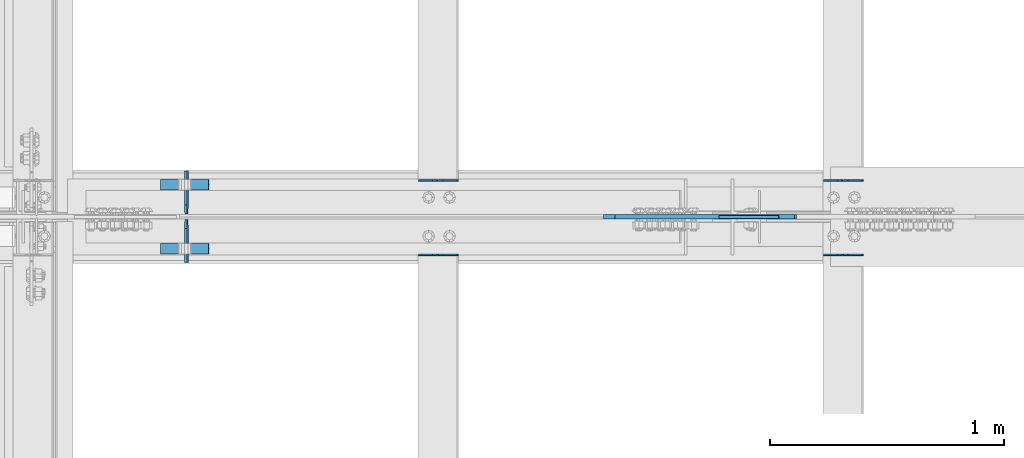
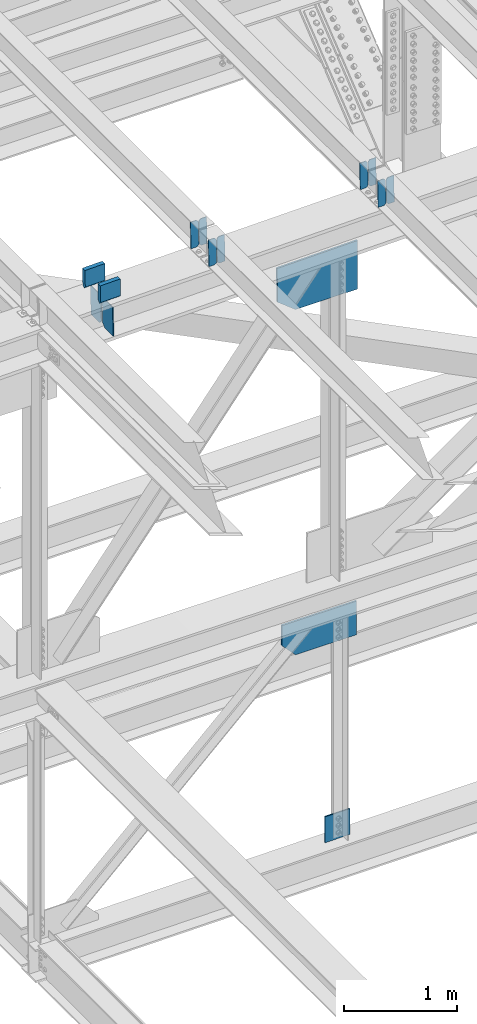
# One storey, part 3610 of 3843: 15 plates, 7 elements without a shape of their own.
"""IFC2X3 building model written with IfcOpenShell, lengths in millimetres."""

from ifc_helpers import new_model, si_unit, frame, origin_with_axes, place, context, subcontext, project, spatial, faceted_brep, material, type_object, element, aggregate, save


model = new_model("IFC2X3")

# Units and contexts
model_context = context("Model", 3, precision=1e-05, world=origin_with_axes())
body_context = subcontext(model_context, "Body", "Model", "MODEL_VIEW")
ifc_project = project(units=[si_unit("LENGTHUNIT", "METRE", prefix="MILLI"), si_unit("AREAUNIT", "SQUARE_METRE"), si_unit("VOLUMEUNIT", "CUBIC_METRE"), si_unit("MASSUNIT", "GRAM", prefix="KILO"), si_unit("TIMEUNIT", "SECOND"), si_unit("PLANEANGLEUNIT", "RADIAN"), si_unit("SOLIDANGLEUNIT", "STERADIAN"), si_unit("THERMODYNAMICTEMPERATUREUNIT", "DEGREE_CELSIUS"), si_unit("LUMINOUSINTENSITYUNIT", "LUMEN")], contexts=[model_context])

# Site, building, storey
site_placement = place(None, origin_with_axes())
site = spatial("IfcSite", under=ifc_project, at=site_placement, CompositionType="ELEMENT")
building_placement = place(site_placement, origin_with_axes())
building = spatial("IfcBuilding", under=site, at=building_placement, Name="Undefined", CompositionType="ELEMENT")
storey_placement = place(building_placement, origin_with_axes())
storey = spatial("IfcBuildingStorey", under=building, at=storey_placement, Name="Undefined", CompositionType="ELEMENT", Elevation=0.0)

# Assembly, plates
assembly_1_placement = place(storey_placement, origin_with_axes())
assembly_1 = element("IfcElementAssembly", 1, at=assembly_1_placement, inside=storey, Name="BEAM", AssemblyPlace="NOTDEFINED", PredefinedType="RIGID_FRAME")
ifc_material = material(Name="STEEL/A572-50")
plate_type_1 = type_object("IfcPlateType", PredefinedType="NOTDEFINED")
plate_1_placement = place(assembly_1_placement, frame((80549.496663406, 67426.8308424063, 46443.9500918996), z_axis=(-0.021152098224542, 0.00215704300087236, 0.999773942402077), x_axis=(-0.999776269356297, -4.57939999836346e-05, -0.021152048007558)))
plate_1 = element("IfcPlate", 2, at=plate_1_placement, type_object=plate_type_1, material=ifc_material, Name="PLATE", context=body_context, shape_type="Brep", body=[
    faceted_brep([(0.0, -3.17499999999927, 0.0), (6.83940015733242e-10, -3.17499999996653, 288.924999998613), (6.54836185276508e-10, 3.17500000001746, 288.924999998591), (0.0, 3.17499999999927, 0.0), (60.3250007643655, -3.17500000017753, 288.924999998606), (60.3250007643219, 3.17499999979918, 288.924999998584), (79.3750000013097, -3.17500000025029, 269.875000761494), (79.375000001266, 3.17499999972642, 269.875000761487), (79.375000000713, -3.17500000026484, 19.0499992370605), (79.3750000006985, 3.17499999971187, 19.0499992370533), (60.325000763667, -3.17500000020664, -1.45519152283669e-11), (60.3250007636234, 3.17499999977736, -3.63797880709171e-11)], [[[0, 1, 2, 3]], [[1, 4, 5, 2]], [[4, 6, 7, 5]], [[6, 8, 9, 7]], [[8, 10, 11, 9]], [[10, 0, 3, 11]], [[5, 7, 9, 11, 3, 2]], [[10, 8, 6, 4, 1, 0]]]),
])
plate_2_placement = place(assembly_1_placement, frame((80463.7908427148, 67426.8269307585, 46442.1368325162), z_axis=(-0.021152098224542, 0.00215704300087236, 0.999773942402077), x_axis=(-0.999776269356297, -4.57939999836346e-05, -0.021152048007558)))
plate_2 = element("IfcPlate", 3, at=plate_2_placement, type_object=plate_type_1, material=ifc_material, Name="PLATE", context=body_context, shape_type="Brep", body=[
    faceted_brep([(4.36557456851006e-11, -3.17499999998836, 19.0499992370969), (6.11180439591408e-10, -3.17499999996653, 269.875000761516), (5.96628524363041e-10, 3.17500000001746, 269.875000761502), (1.45519152283669e-11, 3.17499999998836, 19.0499992370824), (19.0499992376572, -3.17500000003201, 288.924999998606), (19.0499992376281, 3.1749999999447, 288.924999998584), (79.3750000013242, -3.17500000025029, 288.924999998591), (79.3750000013097, 3.1749999997337, 288.92499999857), (79.3750000006548, -3.17500000026484, -2.18278728425503e-11), (79.3750000006403, 3.17499999969732, -2.91038304567337e-11), (19.0499992370023, -3.17500000005384, 0.0), (19.0499992369587, 3.17499999992287, -1.45519152283669e-11)], [[[0, 1, 2, 3]], [[1, 4, 5, 2]], [[4, 6, 7, 5]], [[6, 8, 9, 7]], [[8, 10, 11, 9]], [[10, 0, 3, 11]], [[5, 7, 9, 11, 3, 2]], [[10, 8, 6, 4, 1, 0]]]),
])
aggregate(assembly_1, [plate_1, plate_2])

assembly_2_placement = place(storey_placement, origin_with_axes())
assembly_2 = element("IfcElementAssembly", 4, at=assembly_2_placement, inside=storey, Name="BEAM", AssemblyPlace="NOTDEFINED", PredefinedType="RIGID_FRAME")
plate_3_placement = place(assembly_2_placement, frame((80549.4966586625, 67109.7846024204, 46444.3868867662), z_axis=(-0.0211520982257644, 0.00063245100018685, 0.999776069300711), x_axis=(-0.999776269350183, -1.43399999262055e-05, -0.021152093007418)))
plate_3 = element("IfcPlate", 5, at=plate_3_placement, type_object=plate_type_1, material=ifc_material, Name="PLATE", context=body_context, shape_type="Brep", body=[
    faceted_brep([(0.0, -3.17499999999927, 0.0), (6.83940015733242e-10, -3.17499999996653, 288.924999998613), (6.54836185276508e-10, 3.17500000001746, 288.924999998591), (0.0, 3.17499999999927, 0.0), (60.3250007643655, -3.17500000017753, 288.924999998606), (60.3250007643219, 3.17499999979918, 288.924999998584), (79.3750000013097, -3.17500000025029, 269.875000761494), (79.375000001266, 3.17499999972642, 269.875000761487), (79.375000000713, -3.17500000026484, 19.0499992370605), (79.3750000006985, 3.17499999971187, 19.0499992370533), (60.325000763667, -3.17500000020664, -1.45519152283669e-11), (60.3250007636234, 3.17499999977736, -3.63797880709171e-11)], [[[0, 1, 2, 3]], [[1, 4, 5, 2]], [[4, 6, 7, 5]], [[6, 8, 9, 7]], [[8, 10, 11, 9]], [[10, 0, 3, 11]], [[5, 7, 9, 11, 3, 2]], [[10, 8, 6, 4, 1, 0]]]),
])
plate_4_placement = place(assembly_2_placement, frame((80463.7908379713, 67109.7834572489, 46442.5736235265), z_axis=(-0.0211520982257644, 0.00063245100018685, 0.999776069300711), x_axis=(-0.999776269350183, -1.43399999262055e-05, -0.021152093007418)))
plate_4 = element("IfcPlate", 6, at=plate_4_placement, type_object=plate_type_1, material=ifc_material, Name="PLATE", context=body_context, shape_type="Brep", body=[
    faceted_brep([(4.36557456851006e-11, -3.17499999998836, 19.0499992370969), (6.11180439591408e-10, -3.17499999996653, 269.875000761516), (5.96628524363041e-10, 3.17500000001746, 269.875000761502), (1.45519152283669e-11, 3.17499999998836, 19.0499992370824), (19.0499992376572, -3.17500000003201, 288.924999998606), (19.0499992376281, 3.1749999999447, 288.924999998584), (79.3750000013242, -3.17500000025029, 288.924999998591), (79.3750000013097, 3.1749999997337, 288.92499999857), (79.3750000006548, -3.17500000026484, -2.18278728425503e-11), (79.3750000006403, 3.17499999969732, -2.91038304567337e-11), (19.0499992370023, -3.17500000005384, 0.0), (19.0499992369587, 3.17499999992287, -1.45519152283669e-11)], [[[0, 1, 2, 3]], [[1, 4, 5, 2]], [[4, 6, 7, 5]], [[6, 8, 9, 7]], [[8, 10, 11, 9]], [[10, 0, 3, 11]], [[5, 7, 9, 11, 3, 2]], [[10, 8, 6, 4, 1, 0]]]),
])
aggregate(assembly_2, [plate_3, plate_4])

assembly_3_placement = place(storey_placement, origin_with_axes())
assembly_3 = element("IfcElementAssembly", 7, at=assembly_3_placement, inside=storey, Name="BEAM", AssemblyPlace="NOTDEFINED", PredefinedType="RIGID_FRAME")
plate_5_placement = place(assembly_3_placement, frame((78822.2966634333, 67426.8284519226, 46410.260581113), z_axis=(-0.02115209757931, 0.00216448800069338, 0.999773926325192), x_axis=(-0.999776269356297, -4.57939999836346e-05, -0.021152048007558)))
plate_5 = element("IfcPlate", 8, at=plate_5_placement, type_object=plate_type_1, material=ifc_material, Name="PLATE", context=body_context, shape_type="Brep", body=[
    faceted_brep([(0.0, -3.17499999999927, 0.0), (6.83940015733242e-10, -3.17499999996653, 288.924999998613), (6.54836185276508e-10, 3.17500000001746, 288.924999998591), (0.0, 3.17499999999927, 0.0), (60.3250007643655, -3.17500000017753, 288.924999998606), (60.3250007643219, 3.17499999979918, 288.924999998584), (79.3750000013097, -3.17500000025029, 269.875000761494), (79.375000001266, 3.17499999972642, 269.875000761487), (79.375000000713, -3.17500000026484, 19.0499992370605), (79.3750000006985, 3.17499999971187, 19.0499992370533), (60.325000763667, -3.17500000020664, -1.45519152283669e-11), (60.3250007636234, 3.17499999977736, -3.63797880709171e-11)], [[[0, 1, 2, 3]], [[1, 4, 5, 2]], [[4, 6, 7, 5]], [[6, 8, 9, 7]], [[8, 10, 11, 9]], [[10, 0, 3, 11]], [[5, 7, 9, 11, 3, 2]], [[10, 8, 6, 4, 1, 0]]]),
])
plate_6_placement = place(assembly_3_placement, frame((78736.5908427421, 67426.8245257752, 46408.4473217623), z_axis=(-0.02115209757931, 0.00216448800069338, 0.999773926325192), x_axis=(-0.999776269356297, -4.57939999836346e-05, -0.021152048007558)))
plate_6 = element("IfcPlate", 9, at=plate_6_placement, type_object=plate_type_1, material=ifc_material, Name="PLATE", context=body_context, shape_type="Brep", body=[
    faceted_brep([(4.36557456851006e-11, -3.17499999998836, 19.0499992370969), (6.11180439591408e-10, -3.17499999996653, 269.875000761516), (5.96628524363041e-10, 3.17500000001746, 269.875000761502), (1.45519152283669e-11, 3.17499999998836, 19.0499992370824), (19.0499992376572, -3.17500000003201, 288.924999998606), (19.0499992376281, 3.1749999999447, 288.924999998584), (79.3750000013242, -3.17500000025029, 288.924999998591), (79.3750000013097, 3.1749999997337, 288.92499999857), (79.3750000006548, -3.17500000026484, -2.18278728425503e-11), (79.3750000006403, 3.17499999969732, -2.91038304567337e-11), (19.0499992370023, -3.17500000005384, 0.0), (19.0499992369587, 3.17499999992287, -1.45519152283669e-11)], [[[0, 1, 2, 3]], [[1, 4, 5, 2]], [[4, 6, 7, 5]], [[6, 8, 9, 7]], [[8, 10, 11, 9]], [[10, 0, 3, 11]], [[5, 7, 9, 11, 3, 2]], [[10, 8, 6, 4, 1, 0]]]),
])
aggregate(assembly_3, [plate_5, plate_6])

assembly_4_placement = place(storey_placement, origin_with_axes())
assembly_4 = element("IfcElementAssembly", 10, at=assembly_4_placement, inside=storey, Name="BEAM", AssemblyPlace="NOTDEFINED", PredefinedType="RIGID_FRAME")
plate_7_placement = place(assembly_4_placement, frame((78822.2966586858, 67109.7941256206, 46410.6944025361), z_axis=(-0.0211520978869958, 0.000606560000211177, 0.999776085351088), x_axis=(-0.999776269355723, -1.23390000258365e-05, -0.0211520940075068)))
plate_7 = element("IfcPlate", 11, at=plate_7_placement, type_object=plate_type_1, material=ifc_material, Name="PLATE", context=body_context, shape_type="Brep", body=[
    faceted_brep([(0.0, -3.17499999999927, 0.0), (6.83940015733242e-10, -3.17499999996653, 288.924999998613), (6.54836185276508e-10, 3.17500000001746, 288.924999998591), (0.0, 3.17499999999927, 0.0), (60.3250007643655, -3.17500000017753, 288.924999998606), (60.3250007643219, 3.17499999979918, 288.924999998584), (79.3750000013097, -3.17500000025029, 269.875000761494), (79.375000001266, 3.17499999972642, 269.875000761487), (79.375000000713, -3.17500000026484, 19.0499992370605), (79.3750000006985, 3.17499999971187, 19.0499992370533), (60.325000763667, -3.17500000020664, -1.45519152283669e-11), (60.3250007636234, 3.17499999977736, -3.63797880709171e-11)], [[[0, 1, 2, 3]], [[1, 4, 5, 2]], [[4, 6, 7, 5]], [[6, 8, 9, 7]], [[8, 10, 11, 9]], [[10, 0, 3, 11]], [[5, 7, 9, 11, 3, 2]], [[10, 8, 6, 4, 1, 0]]]),
])
plate_8_placement = place(assembly_4_placement, frame((78736.5908379945, 67109.7930274078, 46408.8811392665), z_axis=(-0.0211520978869958, 0.000606560000211177, 0.999776085351088), x_axis=(-0.999776269355723, -1.23390000258365e-05, -0.0211520940075068)))
plate_8 = element("IfcPlate", 12, at=plate_8_placement, type_object=plate_type_1, material=ifc_material, Name="PLATE", context=body_context, shape_type="Brep", body=[
    faceted_brep([(4.36557456851006e-11, -3.17499999998836, 19.0499992370969), (6.11180439591408e-10, -3.17499999996653, 269.875000761516), (5.96628524363041e-10, 3.17500000001746, 269.875000761502), (1.45519152283669e-11, 3.17499999998836, 19.0499992370824), (19.0499992376572, -3.17500000003201, 288.924999998606), (19.0499992376281, 3.1749999999447, 288.924999998584), (79.3750000013242, -3.17500000025029, 288.924999998591), (79.3750000013097, 3.1749999997337, 288.92499999857), (79.3750000006548, -3.17500000026484, -2.18278728425503e-11), (79.3750000006403, 3.17499999969732, -2.91038304567337e-11), (19.0499992370023, -3.17500000005384, 0.0), (19.0499992369587, 3.17499999992287, -1.45519152283669e-11)], [[[0, 1, 2, 3]], [[1, 4, 5, 2]], [[4, 6, 7, 5]], [[6, 8, 9, 7]], [[8, 10, 11, 9]], [[10, 0, 3, 11]], [[5, 7, 9, 11, 3, 2]], [[10, 8, 6, 4, 1, 0]]]),
])
aggregate(assembly_4, [plate_7, plate_8])

assembly_5_placement = place(storey_placement, origin_with_axes())
assembly_5 = element("IfcElementAssembly", 13, at=assembly_5_placement, inside=storey, Name="BEAM", AssemblyPlace="NOTDEFINED", PredefinedType="RIGID_FRAME")
plate_type_2 = type_object("IfcPlateType", PredefinedType="NOTDEFINED")
plate_9_placement = place(assembly_5_placement, frame((77665.5781783249, 67076.3375, 46022.4469458882), z_axis=(-0.019828109994094, 0.0, 0.999803403701979), x_axis=(0.0, 1.0, 0.0)))
plate_9 = element("IfcPlate", 14, at=plate_9_placement, type_object=plate_type_2, material=ifc_material, Name="PL", context=body_context, shape_type="Brep", body=[
    faceted_brep([(0.0, -4.76249999999709, 0.0), (0.0, -4.76249999986612, 316.896679377329), (0.0, 4.7625000001135, 316.896679377329), (0.0, 4.76249999999709, 0.0), (145.748320007318, -4.76249999986612, 316.896679377329), (145.748320007318, 4.7625000001135, 316.896679377329), (184.149999999994, -4.76249999988067, 278.494999384784), (184.149999999994, 4.76250000009895, 278.494999384777), (184.149999999994, -4.76249999998254, 38.4016799925521), (184.149999999994, 4.76249999999709, 38.4016799925594), (145.748320007318, -4.76249999999709, 7.27595761418343e-12), (145.748320007318, 4.76249999996799, 0.0)], [[[0, 1, 2, 3]], [[1, 4, 5, 2]], [[4, 6, 7, 5]], [[6, 8, 9, 7]], [[8, 10, 11, 9]], [[10, 0, 3, 11]], [[5, 7, 9, 11, 3, 2]], [[10, 8, 6, 4, 1, 0]]]),
])
plate_10_placement = place(assembly_5_placement, frame((77665.5781783249, 67283.3125, 46022.4469458882), z_axis=(-0.019828109994094, 0.0, 0.999803403701979), x_axis=(0.0, 1.0, 0.0)))
plate_10 = element("IfcPlate", 15, at=plate_10_placement, type_object=plate_type_2, material=ifc_material, Name="PL", context=body_context, shape_type="Brep", body=[
    faceted_brep([(0.0, -4.76249999998254, 38.4016799925521), (0.0, -4.76249999988067, 278.494999384784), (0.0, 4.76250000009895, 278.494999384777), (0.0, 4.76249999999709, 38.4016799925594), (38.4016799926758, -4.76249999986612, 316.896679377329), (38.4016799926758, 4.7625000001135, 316.896679377329), (184.149999999994, -4.76249999986612, 316.896679377329), (184.149999999994, 4.7625000001135, 316.896679377329), (184.150000000009, -4.76249999999709, 0.0), (184.150000000009, 4.76249999999709, 0.0), (38.4016799926758, -4.76249999999709, 7.27595761418343e-12), (38.4016799926758, 4.76249999996799, 0.0)], [[[0, 1, 2, 3]], [[1, 4, 5, 2]], [[4, 6, 7, 5]], [[6, 8, 9, 7]], [[8, 10, 11, 9]], [[10, 0, 3, 11]], [[5, 7, 9, 11, 3, 2]], [[10, 8, 6, 4, 1, 0]]]),
])
plate_type_3 = type_object("IfcPlateType", PredefinedType="NOTDEFINED")
plate_11_placement = place(assembly_5_placement, frame((77552.0228938503, 67408.028125, 46583.4639840488), z_axis=(0.0217666070074993, 0.0, -0.999763079343992), x_axis=(0.999763079343992, 0.0, 0.0217666070075027)))
plate_11 = element("IfcPlate", 16, at=plate_11_placement, type_object=plate_type_3, material=ifc_material, Name="PLATE", context=body_context, shape_type="Brep", body=[
    faceted_brep([(203.200005058941, -22.2250000000058, -1.16415321826935e-10), (7.27595761418343e-12, -22.2250000000058, -7.27595761418343e-12), (7.27595761418343e-12, 22.2250000000058, -7.27595761418343e-12), (203.200005058941, 22.2250000000058, -1.16415321826935e-10), (203.838531807472, -22.2250000000058, 0.00187068080413155), (203.838531807472, 22.2250000000058, 0.00187068080413155), (203.310341304641, -22.2250000000058, 180.861817383484), (0.04046799018397, -22.2250000000058, 180.907287948779), (203.245434494536, 0.0133131837355904, 203.086833080139), (0.0454396034692763, 0.0133129994646879, 203.132287829787), (0.0404679902494536, 22.2250000000058, 180.907288225317), (203.310341303353, 22.2250000000058, 180.861817822159)], [[[0, 1, 2, 3]], [[4, 0, 3, 5]], [[1, 0, 4, 6, 7]], [[7, 6, 8, 9]], [[2, 1, 7, 9, 10]], [[5, 3, 2, 10, 11]], [[6, 4, 5, 11, 8]], [[10, 9, 8, 11]]]),
])
plate_12_placement = place(assembly_5_placement, frame((77552.0228938503, 67134.978125, 46583.4639840488), z_axis=(0.0217666070074993, 0.0, -0.999763079343992), x_axis=(0.999763079343992, 0.0, 0.0217666070075027)))
plate_12 = element("IfcPlate", 17, at=plate_12_placement, type_object=plate_type_3, material=ifc_material, Name="PLATE", context=body_context, shape_type="Brep", body=[
    faceted_brep([(203.200005058941, -22.2250000000058, -1.16415321826935e-10), (7.27595761418343e-12, -22.2250000000058, -7.27595761418343e-12), (7.27595761418343e-12, 22.2250000000058, -7.27595761418343e-12), (203.200005058941, 22.2250000000058, -1.16415321826935e-10), (203.838531807472, -22.2250000000058, 0.00187068080413155), (203.838531807472, 22.2250000000058, 0.00187068080413155), (203.310341304641, -22.2250000000058, 180.861817383484), (0.04046799018397, -22.2250000000058, 180.907287948779), (203.245434494536, 0.0133131837355904, 203.086833080139), (0.0454396034692763, 0.0133129994646879, 203.132287829787), (0.0404679902494536, 22.2250000000058, 180.907288225317), (203.310341303353, 22.2250000000058, 180.861817822159)], [[[0, 1, 2, 3]], [[4, 0, 3, 5]], [[1, 0, 4, 6, 7]], [[7, 6, 8, 9]], [[2, 1, 7, 9, 10]], [[5, 3, 2, 10, 11]], [[6, 4, 5, 11, 8]], [[10, 9, 8, 11]]]),
])
plate_type_4 = type_object("IfcPlateType", PredefinedType="NOTDEFINED")
plate_13_placement = place(assembly_5_placement, frame((80263.6228633433, 67271.9, 46033.7256986031), z_axis=(0.0190052740089014, 0.0, -0.999819383468758), x_axis=(-0.999819383468758, 0.0, -0.0190052740089063)))
plate_13 = element("IfcPlate", 18, at=plate_13_placement, type_object=plate_type_4, material=ifc_material, Name="PLATE", context=body_context, shape_type="Brep", body=[
    faceted_brep([(0.0, -9.52500000000146, 0.0), (9.56907637063705, -9.52499999999418, 523.248709936925), (9.56907637063705, 9.52499999999418, 523.248709936925), (0.0, 9.52500000000146, 0.0), (645.096880291487, -9.52499999999418, 511.168148203498), (645.096880291487, 9.52499999999418, 511.168148203498), (822.3103821119, -9.52499999999418, 366.761310303307), (822.3103821119, 9.52499999999418, 366.761310303307), (822.31038211126, -9.52499999999418, -1.28056854009628e-09), (822.31038211126, 9.52499999999418, -1.28056854009628e-09)], [[[0, 1, 2, 3]], [[1, 4, 5, 2]], [[4, 6, 7, 5]], [[6, 8, 9, 7]], [[8, 0, 3, 9]], [[5, 7, 9, 3, 2]], [[8, 6, 4, 1, 0]]]),
])
aggregate(assembly_5, [plate_11, plate_12, plate_9, plate_10, plate_13])

# Assembly, plate
assembly_6_placement = place(storey_placement, origin_with_axes())
assembly_6 = element("IfcElementAssembly", 19, at=assembly_6_placement, inside=storey, Name="BEAM", AssemblyPlace="NOTDEFINED", PredefinedType="RIGID_FRAME")
plate_type_5 = type_object("IfcPlateType", PredefinedType="NOTDEFINED")
plate_14_placement = place(assembly_6_placement, frame((80254.4750000279, 67271.9, 42146.4544348498), z_axis=(-0.00214010699992651, 0.0, -0.999997709968392), x_axis=(-0.999997709968392, 0.0, 0.00214010699993368)))
plate_14 = element("IfcPlate", 20, at=plate_14_placement, type_object=plate_type_5, material=ifc_material, Name="PLATE", context=body_context, shape_type="Brep", body=[
    faceted_brep([(0.0, -9.52500000000146, 0.0), (-0.775064106026548, -9.52499999999418, 362.160586380858), (-0.775064106026548, 9.52499999999418, 362.160586380858), (0.0, 9.52500000000146, 0.0), (623.636141581126, -9.52499999999418, 363.496896104036), (623.636141581126, 9.52499999999418, 363.496896104036), (763.656603908064, -9.52499999999418, 216.240279048696), (763.656603908064, 9.52499999999418, 216.240279048696), (763.656603908661, -9.52499999999418, 2.14640749618411e-09), (763.656603908661, 9.52499999999418, 2.14640749618411e-09)], [[[0, 1, 2, 3]], [[1, 4, 5, 2]], [[4, 6, 7, 5]], [[6, 8, 9, 7]], [[8, 0, 3, 9]], [[5, 7, 9, 3, 2]], [[8, 6, 4, 1, 0]]]),
])
aggregate(assembly_6, [plate_14])

assembly_7_placement = place(storey_placement, origin_with_axes())
assembly_7 = element("IfcElementAssembly", 21, at=assembly_7_placement, inside=storey, Name="BEAM", AssemblyPlace="NOTDEFINED", PredefinedType="RIGID_FRAME")
plate_type_6 = type_object("IfcPlateType", PredefinedType="NOTDEFINED")
plate_15_placement = place(assembly_7_placement, frame((80190.0414157694, 67271.9000007629, 39650.3746017479), z_axis=(-0.00804011299814736, 0.0, 0.999967677769125), x_axis=(-0.999967677769125, 0.0, -0.00804011299814515)))
plate_15 = element("IfcPlate", 22, at=plate_15_placement, type_object=plate_type_6, material=ifc_material, Name="PLATE", context=body_context, shape_type="Brep", body=[
    faceted_brep([(0.0, -6.3499999046162, 0.0), (-5.0931703299284e-10, -6.35000000000582, 278.77913354936), (-5.0931703299284e-10, 6.35000000000582, 278.77913354936), (7.27595761418343e-12, 6.3499999046162, 0.0), (253.991790192624, -6.35000000000582, 280.821322251693), (253.991790192624, 6.35000000000582, 280.821322251693), (256.249698336978, -6.35000000000582, 4.72937244921923e-10), (256.249698336978, 6.35000000000582, 4.72937244921923e-10)], [[[0, 1, 2, 3]], [[1, 4, 5, 2]], [[4, 6, 7, 5]], [[6, 0, 3, 7]], [[5, 7, 3, 2]], [[6, 4, 1, 0]]]),
])
aggregate(assembly_7, [plate_15])

save(model, "model.ifc")
